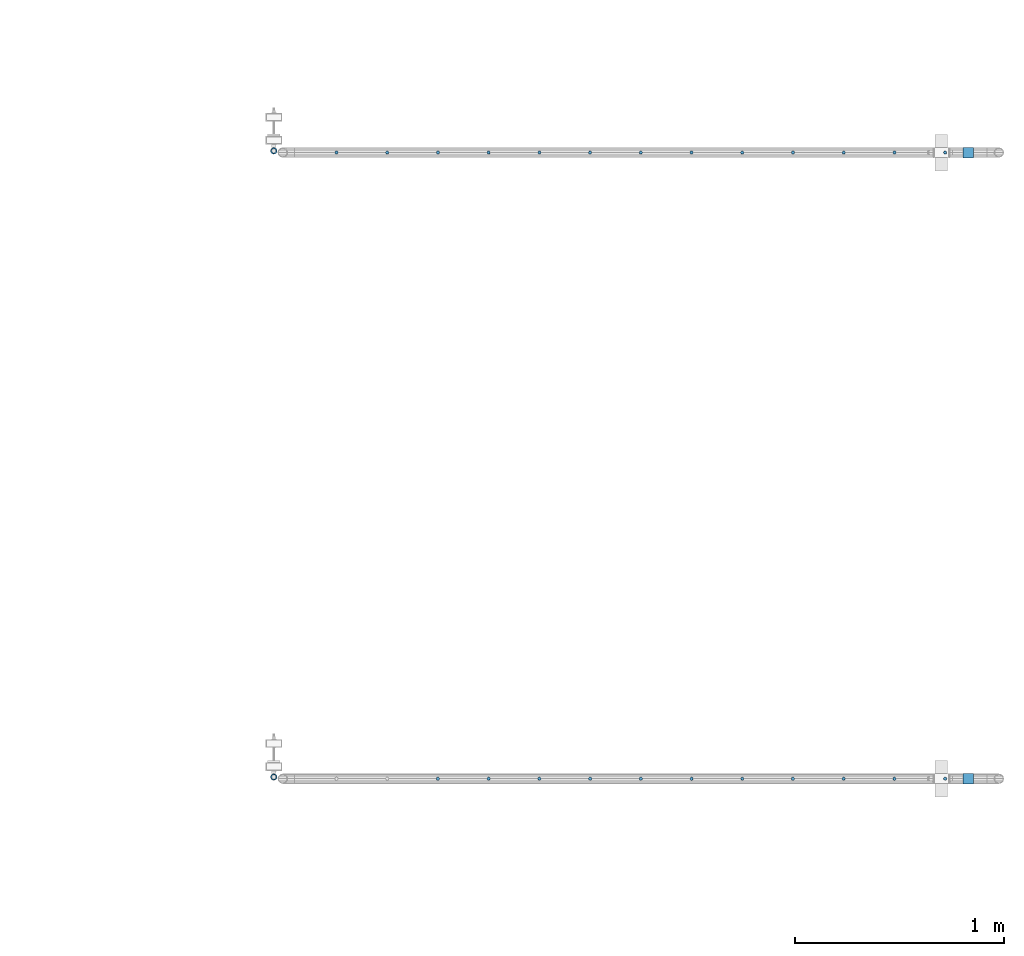
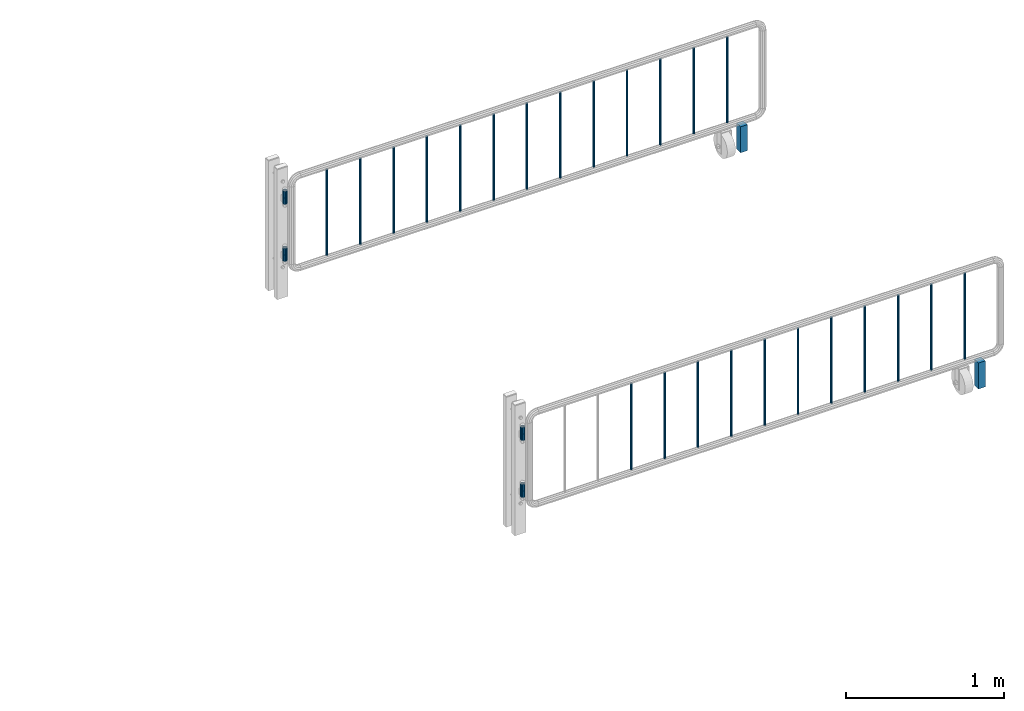
# One storey, part 114 of 270: 34 columns.
"""IFC2X3 building model written with IfcOpenShell, lengths in millimetres."""

from ifc_helpers import new_model, si_unit, frame, origin_with_axes, place, context, subcontext, project, spatial, faceted_brep, material, type_object, element, save


model = new_model("IFC2X3")

# Units and contexts
model_context = context("Model", 3, precision=1e-05, world=origin_with_axes())
body_context = subcontext(model_context, "Body", "Model", "MODEL_VIEW")
ifc_project = project(units=[si_unit("LENGTHUNIT", "METRE", prefix="MILLI"), si_unit("AREAUNIT", "SQUARE_METRE"), si_unit("VOLUMEUNIT", "CUBIC_METRE"), si_unit("MASSUNIT", "GRAM", prefix="KILO"), si_unit("TIMEUNIT", "SECOND"), si_unit("PLANEANGLEUNIT", "RADIAN"), si_unit("SOLIDANGLEUNIT", "STERADIAN"), si_unit("THERMODYNAMICTEMPERATUREUNIT", "DEGREE_CELSIUS"), si_unit("LUMINOUSINTENSITYUNIT", "LUMEN")], contexts=[model_context])

# Site, building, storey
site_placement = place(None, origin_with_axes())
site = spatial("IfcSite", under=ifc_project, at=site_placement, CompositionType="ELEMENT")
building_placement = place(site_placement, origin_with_axes())
building = spatial("IfcBuilding", under=site, at=building_placement, Name="Standard", CompositionType="ELEMENT")
storey_placement = place(building_placement, origin_with_axes())
storey = spatial("IfcBuildingStorey", under=building, at=storey_placement, Name="Undefined", CompositionType="ELEMENT", Elevation=0.0)

# Columns
ifc_material_1 = material(Name="STEEL/S355")
column_type_1 = type_object("IfcColumnType", PredefinedType="NOTDEFINED")
for number, where, z_axis, x_axis in (
    (1, (33755.0962679207, -18058.1466275215, 0.500000000007276), (-1.0, 0.0, 0.0), (0.0, 0.0, 1.0)),
    (2, (33755.0962679207, -15058.1466275215, 0.500000000007276), (-1.0, 0.0, 0.0), (0.0, 0.0, 1.0)),
):
    element("IfcColumn", number, at=place(storey_placement, frame(where, z_axis=z_axis, x_axis=x_axis)), inside=storey, type_object=column_type_1, material=ifc_material_1, context=body_context, shape_type="Brep", body=[
        faceted_brep([(0.0, 25.0, -25.0), (0.0, 25.0, 25.0), (200.0, 25.0, 25.0), (200.0, 25.0, -25.0), (0.0, -25.0, 25.0), (200.0, -25.0, 25.0), (0.0, -25.0, -25.0), (200.0, -25.0, -25.0)], [[[0, 1, 2, 3]], [[1, 4, 5, 2]], [[4, 6, 7, 5]], [[6, 0, 3, 7]], [[5, 7, 3, 2]], [[6, 4, 1, 0]]]),
    ])
ifc_material_2 = material()
column_type_2 = type_object("IfcColumnType", PredefinedType="NOTDEFINED")
column_1_placement = place(storey_placement, frame((30428.7460237801, -18049.9960000038, 310.000000000008), z_axis=(-1.0, 0.0, 0.0), x_axis=(0.0, 0.0, 1.0)))
element("IfcColumn", 3, at=column_1_placement, inside=storey, type_object=column_type_2, material=ifc_material_2, context=body_context, shape_type="Brep", body=[
    faceted_brep([(0.0, -10.0, 0.0), (0.0, -8.66025403784442, 5.0), (50.0, -8.66025403784442, 5.0), (50.0, -10.0, 0.0), (0.0, -5.0, 8.66025403784442), (50.0, -5.0, 8.66025403784442), (0.0, 0.0, 10.0), (50.0, 0.0, 10.0), (0.0, 5.0, 8.66025403784442), (50.0, 5.0, 8.66025403784442), (0.0, 8.66025403784442, 5.0), (50.0, 8.66025403784442, 5.0), (0.0, 10.0, 0.0), (50.0, 10.0, 0.0), (0.0, 8.66025403784442, -5.0), (50.0, 8.66025403784442, -5.0), (0.0, 5.0, -8.66025403784442), (50.0, 5.0, -8.66025403784442), (0.0, 0.0, -10.0), (50.0, 0.0, -10.0), (0.0, -5.0, -8.66025403784442), (50.0, -5.0, -8.66025403784442), (0.0, -8.66025403784442, -5.0), (50.0, -8.66025403784442, -5.0), (0.0, -16.0, 0.0), (0.0, -13.8564064605525, -8.0), (50.0, -13.8564064605525, -8.0), (50.0, -16.0, 0.0), (0.0, -8.0, -13.8564064605525), (50.0, -8.0, -13.8564064605525), (0.0, 0.0, -16.0), (50.0, 0.0, -16.0), (0.0, 8.0, -13.8564064605525), (50.0, 8.0, -13.8564064605525), (0.0, 13.8564064605525, -8.0), (50.0, 13.8564064605525, -8.0), (0.0, 16.0, 0.0), (50.0, 16.0, 0.0), (0.0, 13.8564064605525, 8.0), (50.0, 13.8564064605525, 8.0), (0.0, 8.0, 13.8564064605525), (50.0, 8.0, 13.8564064605525), (0.0, 0.0, 16.0), (50.0, 0.0, 16.0), (0.0, -8.0, 13.8564064605525), (50.0, -8.0, 13.8564064605525), (0.0, -13.8564064605525, 8.0), (50.0, -13.8564064605525, 8.0)], [[[0, 1, 2, 3]], [[1, 4, 5, 2]], [[4, 6, 7, 5]], [[6, 8, 9, 7]], [[8, 10, 11, 9]], [[10, 12, 13, 11]], [[12, 14, 15, 13]], [[14, 16, 17, 15]], [[16, 18, 19, 17]], [[18, 20, 21, 19]], [[20, 22, 23, 21]], [[22, 0, 3, 23]], [[24, 25, 26, 27]], [[25, 28, 29, 26]], [[28, 30, 31, 29]], [[30, 32, 33, 31]], [[32, 34, 35, 33]], [[34, 36, 37, 35]], [[36, 38, 39, 37]], [[38, 40, 41, 39]], [[40, 42, 43, 41]], [[42, 44, 45, 43]], [[44, 46, 47, 45]], [[46, 24, 27, 47]], [[29, 31, 33, 35, 37, 39, 41, 43, 45, 47, 27, 26], [5, 7, 9, 11, 13, 15, 17, 19, 21, 23, 3, 2]], [[46, 44, 42, 40, 38, 36, 34, 32, 30, 28, 25, 24], [22, 20, 18, 16, 14, 12, 10, 8, 6, 4, 1, 0]]]),
])
column_2_placement = place(storey_placement, frame((30428.7460237801, -18049.9960000038, 360.000000000008), z_axis=(-1.0, 0.0, 0.0), x_axis=(0.0, 0.0, 1.0)))
element("IfcColumn", 4, at=column_2_placement, inside=storey, type_object=column_type_2, material=ifc_material_2, context=body_context, shape_type="Brep", body=[
    faceted_brep([(0.0, -10.0, 0.0), (0.0, -8.66025403784442, 5.0), (50.0, -8.66025403784442, 5.0), (50.0, -10.0, 0.0), (0.0, -5.0, 8.66025403784442), (50.0, -5.0, 8.66025403784442), (0.0, 0.0, 10.0), (50.0, 0.0, 10.0), (0.0, 5.0, 8.66025403784442), (50.0, 5.0, 8.66025403784442), (0.0, 8.66025403784442, 5.0), (50.0, 8.66025403784442, 5.0), (0.0, 10.0, 0.0), (50.0, 10.0, 0.0), (0.0, 8.66025403784442, -5.0), (50.0, 8.66025403784442, -5.0), (0.0, 5.0, -8.66025403784442), (50.0, 5.0, -8.66025403784442), (0.0, 0.0, -10.0), (50.0, 0.0, -10.0), (0.0, -5.0, -8.66025403784442), (50.0, -5.0, -8.66025403784442), (0.0, -8.66025403784442, -5.0), (50.0, -8.66025403784442, -5.0), (0.0, -16.0, 0.0), (0.0, -13.8564064605525, -8.0), (50.0, -13.8564064605525, -8.0), (50.0, -16.0, 0.0), (0.0, -8.0, -13.8564064605525), (50.0, -8.0, -13.8564064605525), (0.0, 0.0, -16.0), (50.0, 0.0, -16.0), (0.0, 8.0, -13.8564064605525), (50.0, 8.0, -13.8564064605525), (0.0, 13.8564064605525, -8.0), (50.0, 13.8564064605525, -8.0), (0.0, 16.0, 0.0), (50.0, 16.0, 0.0), (0.0, 13.8564064605525, 8.0), (50.0, 13.8564064605525, 8.0), (0.0, 8.0, 13.8564064605525), (50.0, 8.0, 13.8564064605525), (0.0, 0.0, 16.0), (50.0, 0.0, 16.0), (0.0, -8.0, 13.8564064605525), (50.0, -8.0, 13.8564064605525), (0.0, -13.8564064605525, 8.0), (50.0, -13.8564064605525, 8.0)], [[[0, 1, 2, 3]], [[1, 4, 5, 2]], [[4, 6, 7, 5]], [[6, 8, 9, 7]], [[8, 10, 11, 9]], [[10, 12, 13, 11]], [[12, 14, 15, 13]], [[14, 16, 17, 15]], [[16, 18, 19, 17]], [[18, 20, 21, 19]], [[20, 22, 23, 21]], [[22, 0, 3, 23]], [[24, 25, 26, 27]], [[25, 28, 29, 26]], [[28, 30, 31, 29]], [[30, 32, 33, 31]], [[32, 34, 35, 33]], [[34, 36, 37, 35]], [[36, 38, 39, 37]], [[38, 40, 41, 39]], [[40, 42, 43, 41]], [[42, 44, 45, 43]], [[44, 46, 47, 45]], [[46, 24, 27, 47]], [[29, 31, 33, 35, 37, 39, 41, 43, 45, 47, 27, 26], [5, 7, 9, 11, 13, 15, 17, 19, 21, 23, 3, 2]], [[46, 44, 42, 40, 38, 36, 34, 32, 30, 28, 25, 24], [22, 20, 18, 16, 14, 12, 10, 8, 6, 4, 1, 0]]]),
])
column_3_placement = place(storey_placement, frame((30428.7460237801, -18049.9960000038, 750.000000000008), z_axis=(-1.0, 0.0, 0.0), x_axis=(0.0, 0.0, 1.0)))
element("IfcColumn", 5, at=column_3_placement, inside=storey, type_object=column_type_2, material=ifc_material_2, context=body_context, shape_type="Brep", body=[
    faceted_brep([(0.0, -10.0, 0.0), (0.0, -8.66025403784442, 5.0), (50.0, -8.66025403784442, 5.0), (50.0, -10.0, 0.0), (0.0, -5.0, 8.66025403784442), (50.0, -5.0, 8.66025403784442), (0.0, 0.0, 10.0), (50.0, 0.0, 10.0), (0.0, 5.0, 8.66025403784442), (50.0, 5.0, 8.66025403784442), (0.0, 8.66025403784442, 5.0), (50.0, 8.66025403784442, 5.0), (0.0, 10.0, 0.0), (50.0, 10.0, 0.0), (0.0, 8.66025403784442, -5.0), (50.0, 8.66025403784442, -5.0), (0.0, 5.0, -8.66025403784442), (50.0, 5.0, -8.66025403784442), (0.0, 0.0, -10.0), (50.0, 0.0, -10.0), (0.0, -5.0, -8.66025403784442), (50.0, -5.0, -8.66025403784442), (0.0, -8.66025403784442, -5.0), (50.0, -8.66025403784442, -5.0), (0.0, -16.0, 0.0), (0.0, -13.8564064605525, -8.0), (50.0, -13.8564064605525, -8.0), (50.0, -16.0, 0.0), (0.0, -8.0, -13.8564064605525), (50.0, -8.0, -13.8564064605525), (0.0, 0.0, -16.0), (50.0, 0.0, -16.0), (0.0, 8.0, -13.8564064605525), (50.0, 8.0, -13.8564064605525), (0.0, 13.8564064605525, -8.0), (50.0, 13.8564064605525, -8.0), (0.0, 16.0, 0.0), (50.0, 16.0, 0.0), (0.0, 13.8564064605525, 8.0), (50.0, 13.8564064605525, 8.0), (0.0, 8.0, 13.8564064605525), (50.0, 8.0, 13.8564064605525), (0.0, 0.0, 16.0), (50.0, 0.0, 16.0), (0.0, -8.0, 13.8564064605525), (50.0, -8.0, 13.8564064605525), (0.0, -13.8564064605525, 8.0), (50.0, -13.8564064605525, 8.0)], [[[0, 1, 2, 3]], [[1, 4, 5, 2]], [[4, 6, 7, 5]], [[6, 8, 9, 7]], [[8, 10, 11, 9]], [[10, 12, 13, 11]], [[12, 14, 15, 13]], [[14, 16, 17, 15]], [[16, 18, 19, 17]], [[18, 20, 21, 19]], [[20, 22, 23, 21]], [[22, 0, 3, 23]], [[24, 25, 26, 27]], [[25, 28, 29, 26]], [[28, 30, 31, 29]], [[30, 32, 33, 31]], [[32, 34, 35, 33]], [[34, 36, 37, 35]], [[36, 38, 39, 37]], [[38, 40, 41, 39]], [[40, 42, 43, 41]], [[42, 44, 45, 43]], [[44, 46, 47, 45]], [[46, 24, 27, 47]], [[29, 31, 33, 35, 37, 39, 41, 43, 45, 47, 27, 26], [5, 7, 9, 11, 13, 15, 17, 19, 21, 23, 3, 2]], [[46, 44, 42, 40, 38, 36, 34, 32, 30, 28, 25, 24], [22, 20, 18, 16, 14, 12, 10, 8, 6, 4, 1, 0]]]),
])
column_4_placement = place(storey_placement, frame((30428.7460237801, -18049.9960000038, 800.000000000008), z_axis=(-1.0, 0.0, 0.0), x_axis=(0.0, 0.0, 1.0)))
element("IfcColumn", 6, at=column_4_placement, inside=storey, type_object=column_type_2, material=ifc_material_2, context=body_context, shape_type="Brep", body=[
    faceted_brep([(0.0, -10.0, 0.0), (0.0, -8.66025403784442, 5.0), (50.0, -8.66025403784442, 5.0), (50.0, -10.0, 0.0), (0.0, -5.0, 8.66025403784442), (50.0, -5.0, 8.66025403784442), (0.0, 0.0, 10.0), (50.0, 0.0, 10.0), (0.0, 5.0, 8.66025403784442), (50.0, 5.0, 8.66025403784442), (0.0, 8.66025403784442, 5.0), (50.0, 8.66025403784442, 5.0), (0.0, 10.0, 0.0), (50.0, 10.0, 0.0), (0.0, 8.66025403784442, -5.0), (50.0, 8.66025403784442, -5.0), (0.0, 5.0, -8.66025403784442), (50.0, 5.0, -8.66025403784442), (0.0, 0.0, -10.0), (50.0, 0.0, -10.0), (0.0, -5.0, -8.66025403784442), (50.0, -5.0, -8.66025403784442), (0.0, -8.66025403784442, -5.0), (50.0, -8.66025403784442, -5.0), (0.0, -16.0, 0.0), (0.0, -13.8564064605525, -8.0), (50.0, -13.8564064605525, -8.0), (50.0, -16.0, 0.0), (0.0, -8.0, -13.8564064605525), (50.0, -8.0, -13.8564064605525), (0.0, 0.0, -16.0), (50.0, 0.0, -16.0), (0.0, 8.0, -13.8564064605525), (50.0, 8.0, -13.8564064605525), (0.0, 13.8564064605525, -8.0), (50.0, 13.8564064605525, -8.0), (0.0, 16.0, 0.0), (50.0, 16.0, 0.0), (0.0, 13.8564064605525, 8.0), (50.0, 13.8564064605525, 8.0), (0.0, 8.0, 13.8564064605525), (50.0, 8.0, 13.8564064605525), (0.0, 0.0, 16.0), (50.0, 0.0, 16.0), (0.0, -8.0, 13.8564064605525), (50.0, -8.0, 13.8564064605525), (0.0, -13.8564064605525, 8.0), (50.0, -13.8564064605525, 8.0)], [[[0, 1, 2, 3]], [[1, 4, 5, 2]], [[4, 6, 7, 5]], [[6, 8, 9, 7]], [[8, 10, 11, 9]], [[10, 12, 13, 11]], [[12, 14, 15, 13]], [[14, 16, 17, 15]], [[16, 18, 19, 17]], [[18, 20, 21, 19]], [[20, 22, 23, 21]], [[22, 0, 3, 23]], [[24, 25, 26, 27]], [[25, 28, 29, 26]], [[28, 30, 31, 29]], [[30, 32, 33, 31]], [[32, 34, 35, 33]], [[34, 36, 37, 35]], [[36, 38, 39, 37]], [[38, 40, 41, 39]], [[40, 42, 43, 41]], [[42, 44, 45, 43]], [[44, 46, 47, 45]], [[46, 24, 27, 47]], [[29, 31, 33, 35, 37, 39, 41, 43, 45, 47, 27, 26], [5, 7, 9, 11, 13, 15, 17, 19, 21, 23, 3, 2]], [[46, 44, 42, 40, 38, 36, 34, 32, 30, 28, 25, 24], [22, 20, 18, 16, 14, 12, 10, 8, 6, 4, 1, 0]]]),
])
column_5_placement = place(storey_placement, frame((30428.7460237801, -15049.9960000038, 310.000000000008), z_axis=(-1.0, 0.0, 0.0), x_axis=(0.0, 0.0, 1.0)))
element("IfcColumn", 7, at=column_5_placement, inside=storey, type_object=column_type_2, material=ifc_material_2, context=body_context, shape_type="Brep", body=[
    faceted_brep([(0.0, -10.0, 0.0), (0.0, -8.66025403784442, 5.0), (50.0, -8.66025403784442, 5.0), (50.0, -10.0, 0.0), (0.0, -5.0, 8.66025403784442), (50.0, -5.0, 8.66025403784442), (0.0, 0.0, 10.0), (50.0, 0.0, 10.0), (0.0, 5.0, 8.66025403784442), (50.0, 5.0, 8.66025403784442), (0.0, 8.66025403784442, 5.0), (50.0, 8.66025403784442, 5.0), (0.0, 10.0, 0.0), (50.0, 10.0, 0.0), (0.0, 8.66025403784442, -5.0), (50.0, 8.66025403784442, -5.0), (0.0, 5.0, -8.66025403784442), (50.0, 5.0, -8.66025403784442), (0.0, 0.0, -10.0), (50.0, 0.0, -10.0), (0.0, -5.0, -8.66025403784442), (50.0, -5.0, -8.66025403784442), (0.0, -8.66025403784442, -5.0), (50.0, -8.66025403784442, -5.0), (0.0, -16.0, 0.0), (0.0, -13.8564064605525, -8.0), (50.0, -13.8564064605525, -8.0), (50.0, -16.0, 0.0), (0.0, -8.0, -13.8564064605525), (50.0, -8.0, -13.8564064605525), (0.0, 0.0, -16.0), (50.0, 0.0, -16.0), (0.0, 8.0, -13.8564064605525), (50.0, 8.0, -13.8564064605525), (0.0, 13.8564064605525, -8.0), (50.0, 13.8564064605525, -8.0), (0.0, 16.0, 0.0), (50.0, 16.0, 0.0), (0.0, 13.8564064605525, 8.0), (50.0, 13.8564064605525, 8.0), (0.0, 8.0, 13.8564064605525), (50.0, 8.0, 13.8564064605525), (0.0, 0.0, 16.0), (50.0, 0.0, 16.0), (0.0, -8.0, 13.8564064605525), (50.0, -8.0, 13.8564064605525), (0.0, -13.8564064605525, 8.0), (50.0, -13.8564064605525, 8.0)], [[[0, 1, 2, 3]], [[1, 4, 5, 2]], [[4, 6, 7, 5]], [[6, 8, 9, 7]], [[8, 10, 11, 9]], [[10, 12, 13, 11]], [[12, 14, 15, 13]], [[14, 16, 17, 15]], [[16, 18, 19, 17]], [[18, 20, 21, 19]], [[20, 22, 23, 21]], [[22, 0, 3, 23]], [[24, 25, 26, 27]], [[25, 28, 29, 26]], [[28, 30, 31, 29]], [[30, 32, 33, 31]], [[32, 34, 35, 33]], [[34, 36, 37, 35]], [[36, 38, 39, 37]], [[38, 40, 41, 39]], [[40, 42, 43, 41]], [[42, 44, 45, 43]], [[44, 46, 47, 45]], [[46, 24, 27, 47]], [[29, 31, 33, 35, 37, 39, 41, 43, 45, 47, 27, 26], [5, 7, 9, 11, 13, 15, 17, 19, 21, 23, 3, 2]], [[46, 44, 42, 40, 38, 36, 34, 32, 30, 28, 25, 24], [22, 20, 18, 16, 14, 12, 10, 8, 6, 4, 1, 0]]]),
])
column_6_placement = place(storey_placement, frame((30428.7460237801, -15049.9960000038, 360.000000000008), z_axis=(-1.0, 0.0, 0.0), x_axis=(0.0, 0.0, 1.0)))
element("IfcColumn", 8, at=column_6_placement, inside=storey, type_object=column_type_2, material=ifc_material_2, context=body_context, shape_type="Brep", body=[
    faceted_brep([(0.0, -10.0, 0.0), (0.0, -8.66025403784442, 5.0), (50.0, -8.66025403784442, 5.0), (50.0, -10.0, 0.0), (0.0, -5.0, 8.66025403784442), (50.0, -5.0, 8.66025403784442), (0.0, 0.0, 10.0), (50.0, 0.0, 10.0), (0.0, 5.0, 8.66025403784442), (50.0, 5.0, 8.66025403784442), (0.0, 8.66025403784442, 5.0), (50.0, 8.66025403784442, 5.0), (0.0, 10.0, 0.0), (50.0, 10.0, 0.0), (0.0, 8.66025403784442, -5.0), (50.0, 8.66025403784442, -5.0), (0.0, 5.0, -8.66025403784442), (50.0, 5.0, -8.66025403784442), (0.0, 0.0, -10.0), (50.0, 0.0, -10.0), (0.0, -5.0, -8.66025403784442), (50.0, -5.0, -8.66025403784442), (0.0, -8.66025403784442, -5.0), (50.0, -8.66025403784442, -5.0), (0.0, -16.0, 0.0), (0.0, -13.8564064605525, -8.0), (50.0, -13.8564064605525, -8.0), (50.0, -16.0, 0.0), (0.0, -8.0, -13.8564064605525), (50.0, -8.0, -13.8564064605525), (0.0, 0.0, -16.0), (50.0, 0.0, -16.0), (0.0, 8.0, -13.8564064605525), (50.0, 8.0, -13.8564064605525), (0.0, 13.8564064605525, -8.0), (50.0, 13.8564064605525, -8.0), (0.0, 16.0, 0.0), (50.0, 16.0, 0.0), (0.0, 13.8564064605525, 8.0), (50.0, 13.8564064605525, 8.0), (0.0, 8.0, 13.8564064605525), (50.0, 8.0, 13.8564064605525), (0.0, 0.0, 16.0), (50.0, 0.0, 16.0), (0.0, -8.0, 13.8564064605525), (50.0, -8.0, 13.8564064605525), (0.0, -13.8564064605525, 8.0), (50.0, -13.8564064605525, 8.0)], [[[0, 1, 2, 3]], [[1, 4, 5, 2]], [[4, 6, 7, 5]], [[6, 8, 9, 7]], [[8, 10, 11, 9]], [[10, 12, 13, 11]], [[12, 14, 15, 13]], [[14, 16, 17, 15]], [[16, 18, 19, 17]], [[18, 20, 21, 19]], [[20, 22, 23, 21]], [[22, 0, 3, 23]], [[24, 25, 26, 27]], [[25, 28, 29, 26]], [[28, 30, 31, 29]], [[30, 32, 33, 31]], [[32, 34, 35, 33]], [[34, 36, 37, 35]], [[36, 38, 39, 37]], [[38, 40, 41, 39]], [[40, 42, 43, 41]], [[42, 44, 45, 43]], [[44, 46, 47, 45]], [[46, 24, 27, 47]], [[29, 31, 33, 35, 37, 39, 41, 43, 45, 47, 27, 26], [5, 7, 9, 11, 13, 15, 17, 19, 21, 23, 3, 2]], [[46, 44, 42, 40, 38, 36, 34, 32, 30, 28, 25, 24], [22, 20, 18, 16, 14, 12, 10, 8, 6, 4, 1, 0]]]),
])
column_7_placement = place(storey_placement, frame((30428.7460237801, -15049.9960000038, 750.000000000008), z_axis=(-1.0, 0.0, 0.0), x_axis=(0.0, 0.0, 1.0)))
element("IfcColumn", 9, at=column_7_placement, inside=storey, type_object=column_type_2, material=ifc_material_2, context=body_context, shape_type="Brep", body=[
    faceted_brep([(0.0, -10.0, 0.0), (0.0, -8.66025403784442, 5.0), (50.0, -8.66025403784442, 5.0), (50.0, -10.0, 0.0), (0.0, -5.0, 8.66025403784442), (50.0, -5.0, 8.66025403784442), (0.0, 0.0, 10.0), (50.0, 0.0, 10.0), (0.0, 5.0, 8.66025403784442), (50.0, 5.0, 8.66025403784442), (0.0, 8.66025403784442, 5.0), (50.0, 8.66025403784442, 5.0), (0.0, 10.0, 0.0), (50.0, 10.0, 0.0), (0.0, 8.66025403784442, -5.0), (50.0, 8.66025403784442, -5.0), (0.0, 5.0, -8.66025403784442), (50.0, 5.0, -8.66025403784442), (0.0, 0.0, -10.0), (50.0, 0.0, -10.0), (0.0, -5.0, -8.66025403784442), (50.0, -5.0, -8.66025403784442), (0.0, -8.66025403784442, -5.0), (50.0, -8.66025403784442, -5.0), (0.0, -16.0, 0.0), (0.0, -13.8564064605525, -8.0), (50.0, -13.8564064605525, -8.0), (50.0, -16.0, 0.0), (0.0, -8.0, -13.8564064605525), (50.0, -8.0, -13.8564064605525), (0.0, 0.0, -16.0), (50.0, 0.0, -16.0), (0.0, 8.0, -13.8564064605525), (50.0, 8.0, -13.8564064605525), (0.0, 13.8564064605525, -8.0), (50.0, 13.8564064605525, -8.0), (0.0, 16.0, 0.0), (50.0, 16.0, 0.0), (0.0, 13.8564064605525, 8.0), (50.0, 13.8564064605525, 8.0), (0.0, 8.0, 13.8564064605525), (50.0, 8.0, 13.8564064605525), (0.0, 0.0, 16.0), (50.0, 0.0, 16.0), (0.0, -8.0, 13.8564064605525), (50.0, -8.0, 13.8564064605525), (0.0, -13.8564064605525, 8.0), (50.0, -13.8564064605525, 8.0)], [[[0, 1, 2, 3]], [[1, 4, 5, 2]], [[4, 6, 7, 5]], [[6, 8, 9, 7]], [[8, 10, 11, 9]], [[10, 12, 13, 11]], [[12, 14, 15, 13]], [[14, 16, 17, 15]], [[16, 18, 19, 17]], [[18, 20, 21, 19]], [[20, 22, 23, 21]], [[22, 0, 3, 23]], [[24, 25, 26, 27]], [[25, 28, 29, 26]], [[28, 30, 31, 29]], [[30, 32, 33, 31]], [[32, 34, 35, 33]], [[34, 36, 37, 35]], [[36, 38, 39, 37]], [[38, 40, 41, 39]], [[40, 42, 43, 41]], [[42, 44, 45, 43]], [[44, 46, 47, 45]], [[46, 24, 27, 47]], [[29, 31, 33, 35, 37, 39, 41, 43, 45, 47, 27, 26], [5, 7, 9, 11, 13, 15, 17, 19, 21, 23, 3, 2]], [[46, 44, 42, 40, 38, 36, 34, 32, 30, 28, 25, 24], [22, 20, 18, 16, 14, 12, 10, 8, 6, 4, 1, 0]]]),
])
column_8_placement = place(storey_placement, frame((30428.7460237801, -15049.9960000038, 800.000000000008), z_axis=(-1.0, 0.0, 0.0), x_axis=(0.0, 0.0, 1.0)))
element("IfcColumn", 10, at=column_8_placement, inside=storey, type_object=column_type_2, material=ifc_material_2, context=body_context, shape_type="Brep", body=[
    faceted_brep([(0.0, -10.0, 0.0), (0.0, -8.66025403784442, 5.0), (50.0, -8.66025403784442, 5.0), (50.0, -10.0, 0.0), (0.0, -5.0, 8.66025403784442), (50.0, -5.0, 8.66025403784442), (0.0, 0.0, 10.0), (50.0, 0.0, 10.0), (0.0, 5.0, 8.66025403784442), (50.0, 5.0, 8.66025403784442), (0.0, 8.66025403784442, 5.0), (50.0, 8.66025403784442, 5.0), (0.0, 10.0, 0.0), (50.0, 10.0, 0.0), (0.0, 8.66025403784442, -5.0), (50.0, 8.66025403784442, -5.0), (0.0, 5.0, -8.66025403784442), (50.0, 5.0, -8.66025403784442), (0.0, 0.0, -10.0), (50.0, 0.0, -10.0), (0.0, -5.0, -8.66025403784442), (50.0, -5.0, -8.66025403784442), (0.0, -8.66025403784442, -5.0), (50.0, -8.66025403784442, -5.0), (0.0, -16.0, 0.0), (0.0, -13.8564064605525, -8.0), (50.0, -13.8564064605525, -8.0), (50.0, -16.0, 0.0), (0.0, -8.0, -13.8564064605525), (50.0, -8.0, -13.8564064605525), (0.0, 0.0, -16.0), (50.0, 0.0, -16.0), (0.0, 8.0, -13.8564064605525), (50.0, 8.0, -13.8564064605525), (0.0, 13.8564064605525, -8.0), (50.0, 13.8564064605525, -8.0), (0.0, 16.0, 0.0), (50.0, 16.0, 0.0), (0.0, 13.8564064605525, 8.0), (50.0, 13.8564064605525, 8.0), (0.0, 8.0, 13.8564064605525), (50.0, 8.0, 13.8564064605525), (0.0, 0.0, 16.0), (50.0, 0.0, 16.0), (0.0, -8.0, 13.8564064605525), (50.0, -8.0, 13.8564064605525), (0.0, -13.8564064605525, 8.0), (50.0, -13.8564064605525, 8.0)], [[[0, 1, 2, 3]], [[1, 4, 5, 2]], [[4, 6, 7, 5]], [[6, 8, 9, 7]], [[8, 10, 11, 9]], [[10, 12, 13, 11]], [[12, 14, 15, 13]], [[14, 16, 17, 15]], [[16, 18, 19, 17]], [[18, 20, 21, 19]], [[20, 22, 23, 21]], [[22, 0, 3, 23]], [[24, 25, 26, 27]], [[25, 28, 29, 26]], [[28, 30, 31, 29]], [[30, 32, 33, 31]], [[32, 34, 35, 33]], [[34, 36, 37, 35]], [[36, 38, 39, 37]], [[38, 40, 41, 39]], [[40, 42, 43, 41]], [[42, 44, 45, 43]], [[44, 46, 47, 45]], [[46, 24, 27, 47]], [[29, 31, 33, 35, 37, 39, 41, 43, 45, 47, 27, 26], [5, 7, 9, 11, 13, 15, 17, 19, 21, 23, 3, 2]], [[46, 44, 42, 40, 38, 36, 34, 32, 30, 28, 25, 24], [22, 20, 18, 16, 14, 12, 10, 8, 6, 4, 1, 0]]]),
])
ifc_material_3 = material(Name="STEEL/S355J2")
column_type_3 = type_object("IfcColumnType", Name="D16", PredefinedType="NOTDEFINED")
for number, where, z_axis, x_axis in (
    (11, (31215.0960237801, -18058.1460000038, 248.800000000007), (-1.0, 0.0, 0.0), (0.0, 0.0, 1.0)),
    (12, (31458.0960237801, -18058.1460000038, 248.800000000007), (-1.0, 0.0, 0.0), (0.0, 0.0, 1.0)),
    (13, (31701.0960237801, -18058.1460000038, 248.800000000007), (-1.0, 0.0, 0.0), (0.0, 0.0, 1.0)),
    (14, (31944.0960237801, -18058.1460000038, 248.800000000007), (-1.0, 0.0, 0.0), (0.0, 0.0, 1.0)),
    (15, (32187.0960237801, -18058.1460000038, 248.800000000007), (-1.0, 0.0, 0.0), (0.0, 0.0, 1.0)),
    (16, (32430.0960237801, -18058.1460000038, 248.800000000007), (-1.0, 0.0, 0.0), (0.0, 0.0, 1.0)),
    (17, (32673.0960237801, -18058.1460000038, 248.800000000007), (-1.0, 0.0, 0.0), (0.0, 0.0, 1.0)),
    (18, (32916.0960237801, -18058.1460000038, 248.800000000007), (-1.0, 0.0, 0.0), (0.0, 0.0, 1.0)),
    (19, (33159.0960237801, -18058.1460000038, 248.800000000007), (-1.0, 0.0, 0.0), (0.0, 0.0, 1.0)),
    (20, (33402.0960237801, -18058.1460000038, 248.800000000007), (-1.0, 0.0, 0.0), (0.0, 0.0, 1.0)),
    (21, (33645.0960237801, -18058.1460000038, 248.800000000007), (-1.0, 0.0, 0.0), (0.0, 0.0, 1.0)),
    (22, (30729.0960237801, -15058.1460000038, 248.800000000007), (-1.0, 0.0, 0.0), (0.0, 0.0, 1.0)),
    (23, (30972.0960237801, -15058.1460000038, 248.800000000007), (-1.0, 0.0, 0.0), (0.0, 0.0, 1.0)),
    (24, (31215.0960237801, -15058.1460000038, 248.800000000007), (-1.0, 0.0, 0.0), (0.0, 0.0, 1.0)),
    (25, (31458.0960237801, -15058.1460000038, 248.800000000007), (-1.0, 0.0, 0.0), (0.0, 0.0, 1.0)),
    (26, (31701.0960237801, -15058.1460000038, 248.800000000007), (-1.0, 0.0, 0.0), (0.0, 0.0, 1.0)),
    (27, (31944.0960237801, -15058.1460000038, 248.800000000007), (-1.0, 0.0, 0.0), (0.0, 0.0, 1.0)),
    (28, (32187.0960237801, -15058.1460000038, 248.800000000007), (-1.0, 0.0, 0.0), (0.0, 0.0, 1.0)),
    (29, (32430.0960237801, -15058.1460000038, 248.800000000007), (-1.0, 0.0, 0.0), (0.0, 0.0, 1.0)),
    (30, (32673.0960237801, -15058.1460000038, 248.800000000007), (-1.0, 0.0, 0.0), (0.0, 0.0, 1.0)),
    (31, (32916.0960237801, -15058.1460000038, 248.800000000007), (-1.0, 0.0, 0.0), (0.0, 0.0, 1.0)),
    (32, (33159.0960237801, -15058.1460000038, 248.800000000007), (-1.0, 0.0, 0.0), (0.0, 0.0, 1.0)),
    (33, (33402.0960237801, -15058.1460000038, 248.800000000007), (-1.0, 0.0, 0.0), (0.0, 0.0, 1.0)),
    (34, (33645.0960237801, -15058.1460000038, 248.800000000007), (-1.0, 0.0, 0.0), (0.0, 0.0, 1.0)),
):
    element("IfcColumn", number, at=place(storey_placement, frame(where, z_axis=z_axis, x_axis=x_axis)), inside=storey, type_object=column_type_3, material=ifc_material_3, ObjectType="D16", context=body_context, shape_type="Brep", body=[
        faceted_brep([(0.0, -8.0, 0.0), (0.0, -5.65685424949334, -5.65685424949334), (663.0, -5.65685424949334, -5.65685424949334), (663.0, -8.0, 0.0), (0.0, 0.0, -8.0), (663.0, 0.0, -8.0), (0.0, 5.65685424949334, -5.65685424949334), (663.0, 5.65685424949334, -5.65685424949334), (0.0, 8.0, 0.0), (663.0, 8.0, 0.0), (0.0, 5.65685424949334, 5.65685424949334), (663.0, 5.65685424949334, 5.65685424949334), (0.0, 0.0, 8.0), (663.0, 0.0, 8.0), (0.0, -5.65685424949334, 5.65685424949334), (663.0, -5.65685424949334, 5.65685424949334)], [[[0, 1, 2, 3]], [[1, 4, 5, 2]], [[4, 6, 7, 5]], [[6, 8, 9, 7]], [[8, 10, 11, 9]], [[10, 12, 13, 11]], [[12, 14, 15, 13]], [[14, 0, 3, 15]], [[5, 7, 9, 11, 13, 15, 3, 2]], [[14, 12, 10, 8, 6, 4, 1, 0]]]),
    ])

save(model, "model.ifc")
